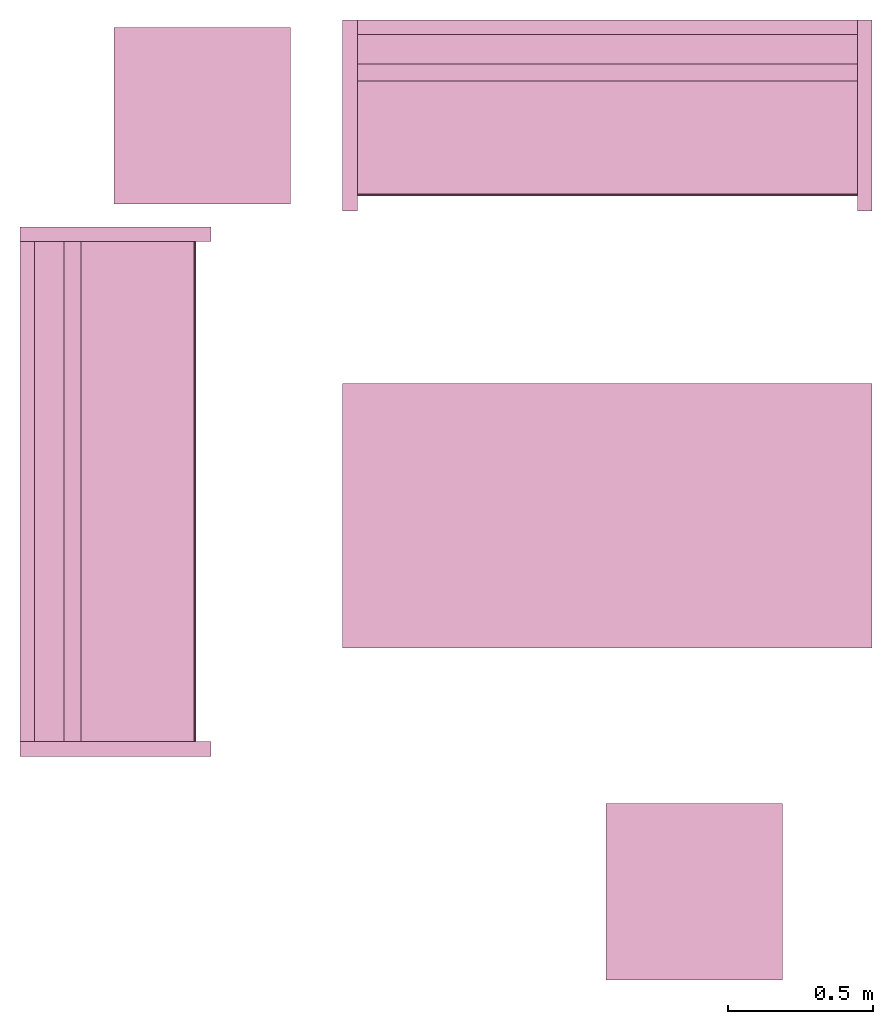
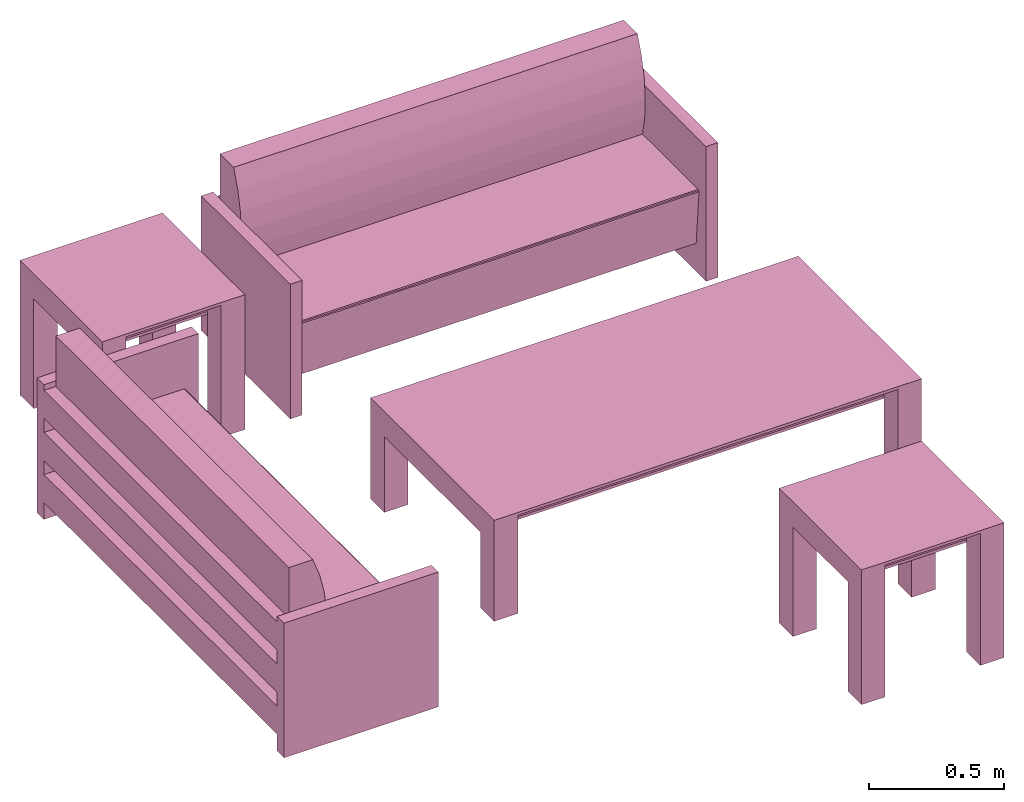
# One storey: 5 furnishings.
"""IFC2X3 building model written with IfcOpenShell, lengths in metres."""

from ifc_helpers import new_model, entity, si_unit, converted_unit, frame, origin, origin_with_axes, origin_2d_with_axis, place, context, project, spatial, polyline, rectangle, outline, extrude, face_set, surface_model, source, transform, mapped, type_object, type_shapes, element, save


model = new_model("IFC2X3")

# Units and contexts
model_context = context("Model", 3, precision=1e-09, world=origin())
plan_context = context("Plan", 3, precision=1e-09, world=origin())
ifc_project = project(units=[si_unit("LENGTHUNIT", "METRE"), si_unit("AREAUNIT", "SQUARE_METRE"), si_unit("VOLUMEUNIT", "CUBIC_METRE"), converted_unit("PLANEANGLEUNIT", "DEGREE", entity("IfcRatioMeasure", 0.0174532925199433), si_unit("PLANEANGLEUNIT", "RADIAN"), dimensions=[0, 0, 0, 0, 0, 0, 0]), si_unit("TIMEUNIT", "SECOND")], contexts=[model_context, plan_context])

# Site, building, storey, space
site_placement = place(None, origin_with_axes())
site = spatial("IfcSite", under=ifc_project, at=site_placement, CompositionType="ELEMENT")
building_placement = place(None, origin_with_axes())
building = spatial("IfcBuilding", under=site, at=building_placement, CompositionType="ELEMENT")
storey_placement = place(None, origin_with_axes())
storey = spatial("IfcBuildingStorey", under=building, at=storey_placement, Name="Level 1", CompositionType="ELEMENT", Elevation=0.0)
space_placement = place(None, origin_with_axes())
space = spatial("IfcSpace", under=storey, at=space_placement, CompositionType="ELEMENT", InteriorOrExteriorSpace="INTERNAL")

# Furnishings
furniture_type_1 = type_object("IfcFurnitureType", Name="0610 x 0610 x 0610mm", AssemblyPlace="NOTDEFINED")
shared_shape_1 = source(origin(), model_context, "Body", "SweptSolid", [
    extrude(rectangle(XDim=0.406799999999999, YDim=0.406799999999999, at=origin_2d_with_axis()), frame((0.0182657666726316, 0.0952110778022263, 0.4957), z_axis=(0.0, 0.0, 1.0), x_axis=(-1.0, 0.0, 0.0)), (0.0, 0.0, 1.0), 0.0127),
    extrude(outline(polyline([(-0.273249999999994, -0.305), (0.324049999999978, -0.305), (0.324049999999978, 0.304999999999998), (-0.273249999999993, 0.304999999999999), (-0.273249999999993, 0.203400000000001), (0.222450000000009, 0.203400000000001), (0.222450000000009, -0.2034), (-0.273249999999994, -0.2034), (-0.273249999999994, -0.305)])), frame((0.221665766672633, 0.0952110778022354, 0.273249999999992), z_axis=(1.0, 0.0, 0.0), x_axis=(0.0, 0.0, 1.0)), (0.0, 0.0, 1.0), 0.1016),
    extrude(outline(polyline([(-0.305000000000004, -0.324050000000025), (0.304999999999994, -0.324050000000025), (0.304999999999994, 0.273250000000011), (0.203400000000004, 0.273250000000011), (0.203400000000004, -0.222449999999996), (-0.203399999999995, -0.222449999999996), (-0.203399999999995, 0.273250000000011), (-0.305000000000004, 0.273250000000011), (-0.305000000000004, -0.324050000000025)])), frame((-0.286734233327367, 0.0952110778022256, 0.273250000000008), z_axis=(1.0, 0.0, 0.0), x_axis=(0.0, -1.0, 0.0)), (0.0, 0.0, 1.0), 0.1016),
    extrude(rectangle(XDim=0.406799999999999, YDim=0.406799999999999, at=origin_2d_with_axis()), frame((0.0182657666726316, 0.0952110778022259, 0.5973), z_axis=(0.0, 0.0, 1.0), x_axis=(-1.0, 0.0, 0.0)), (0.0, 0.0, 1.0), 0.0127),
    extrude(outline(polyline([(-0.305, -0.305000000000023), (0.305, -0.305000000000023), (0.305, 0.305000000000023), (-0.305, 0.305000000000023), (-0.305, -0.305000000000023)]), holes=[polyline([(-0.203399999999998, -0.203399999999975), (-0.203399999999998, 0.203400000000025), (0.203400000000001, 0.203400000000025), (0.203400000000001, -0.203399999999975), (-0.203399999999998, -0.203399999999975)])]), frame((0.0182657666726332, 0.0952110778022508, 0.5973), z_axis=(0.0, 0.0, 1.0), x_axis=(-1.0, 0.0, 0.0)), (0.0, 0.0, 1.0), 0.0127),
])
type_shapes(furniture_type_1, [shared_shape_1])
furnishing_1_placement = place(space_placement, frame((2.9191650807394, -16.6431715869351, 0.0), z_axis=(0.0, 0.0, 1.0), x_axis=(-1.0, 0.0, 0.0)))
element("IfcFurnishingElement", 1, at=furnishing_1_placement, inside=space, type_object=furniture_type_1, Name="M_Table-Coffee:0610 x 0610 x 0610mm:0610 x 0610 x 0610mm", context=model_context, shape_type="MappedRepresentation", body=[
    mapped(shared_shape_1, transform((0.0, 0.0, 0.0), scale=1.0)),
])
furnishing_2_placement = place(None, frame((1.21916508073938, -13.9601715869351, 0.0), z_axis=(0.0, 0.0, 1.0), x_axis=(-1.0, 0.0, 0.0)))
element("IfcFurnishingElement", 2, at=furnishing_2_placement, inside=space, type_object=furniture_type_1, Name="M_Table-Coffee:0610 x 0610 x 0610mm:0610 x 0610 x 0610mm", context=model_context, shape_type="MappedRepresentation", body=[
    mapped(shared_shape_1, transform((0.0, 0.0, 0.0), scale=1.0)),
])
furniture_type_2 = type_object("IfcFurnitureType", Name="1830mm", AssemblyPlace="NOTDEFINED")
shared_shape_2 = source(origin(), model_context, "Body", "SurfaceModel", [
    surface_model("IfcFaceBasedSurfaceModel", [(0.0507999999999982, 0.609599999999997, 0.5842), (0.0507999999999983, 0.660399999999998, 0.5842), (0.0507999999999983, 0.660399999999998, 0.4572), (0.0507999999999982, 0.609599999999997, 0.4572), (0.0507999999999982, 0.609599999999998, 0.3937), (0.0507999999999983, 0.660399999999998, 0.3937), (0.0507999999999983, 0.660399999999998, 0.2667), (0.0507999999999982, 0.609599999999998, 0.2667), (0.0507999999999982, 0.609600000000004, 0.2032), (0.0507999999999983, 0.660399999999998, 0.2032), (0.0507999999999983, 0.660399999999998, 0.0762), (0.0507999999999982, 0.609600000000004, 0.0762), (1.77919999999999, 0.609599999999994, 0.5842), (1.77919999999999, 0.609599999999994, 0.4572), (1.77919999999999, 0.660399999999995, 0.4572), (1.77919999999999, 0.660399999999995, 0.5842), (1.77919999999999, 0.609599999999995, 0.3937), (1.77919999999999, 0.609599999999995, 0.2667), (1.77919999999999, 0.660399999999995, 0.2667), (1.77919999999999, 0.660399999999995, 0.3937), (1.77919999999999, 0.609600000000001, 0.2032), (1.77919999999999, 0.609600000000001, 0.0762), (1.77919999999999, 0.660399999999995, 0.0762), (1.77919999999999, 0.660399999999995, 0.2032), (0.0507999999999978, 0.470222395089521, 0.380999999999998), (0.0507999999999978, 0.454401348887885, 0.467831162756508), (0.0507999999999978, 0.450300415835913, 0.555996567971167), (0.0507999999999978, 0.457992845249543, 0.643921438504357), (0.0507999999999978, 0.477341237862486, 0.730035293556011), (0.0507999999999979, 0.507999999999975, 0.812799999999995), (0.0507999999999981, 0.609599999999998, 0.812799999999998), (0.0507999999999981, 0.609599999999998, 0.127966546684697), (0.0507999999999971, 0.0729375586579064, 0.127966546684697), (0.0507999999999971, 0.0520079452978146, 0.367193122067106), (0.0507999999999971, 0.0526336053189921, 0.372382281209352), (0.0507999999999971, 0.0552961957860913, 0.37687999563672), (0.0507999999999971, 0.0595447350023739, 0.379924455784818), (0.0507999999999971, 0.0646596179635799, 0.381000000000001), (1.77919999999998, 0.470222395089517, 0.381000000000001), (1.77919999999998, 0.0646596179635769, 0.381000000000001), (1.77919999999998, 0.059544735002371, 0.379924455784818), (1.77919999999998, 0.0552961957860883, 0.37687999563672), (1.77919999999998, 0.0526336053189891, 0.372382281209352), (1.77919999999998, 0.0520079452978117, 0.367193122067106), (1.77919999999998, 0.0729375586579034, 0.127966546684697), (1.77919999999998, 0.609599999999995, 0.127966546684697), (1.77919999999998, 0.609599999999995, 0.812799999999998), (1.77919999999998, 0.507999999999972, 0.812799999999995), (1.77919999999998, 0.477341237862483, 0.730035293556011), (1.77919999999998, 0.45799284524954, 0.643921438504357), (1.77919999999998, 0.45030041583591, 0.555996567971167), (1.77919999999998, 0.454401348887882, 0.467831162756508), (0.050799984484911, 0.0539648979902268, 0.374631136655807), (1.77919995784759, 0.0539648979902268, 0.374631136655807), (0.050799984484911, 0.0523207746446133, 0.369787722826004), (1.77919995784759, 0.0523207746446133, 0.369787722826004), (1.77919995784759, 0.0621021725237369, 0.380462229251862), (0.050799984484911, 0.0621788389980793, 0.380478352308273), (1.77919995784759, 0.0574204623699188, 0.378402233123779), (0.050799984484911, 0.0574204623699188, 0.378402233123779), (0.0507999999999971, 0.660399999999997, 0.6096), (0.0507999999999971, 0.0, 0.6096), (0.0, 0.0, 0.6096), (0.0, 0.660399999999997, 0.6096), (1.83, 0.660400000000039, 0.6096), (1.83, 0.0, 0.6096), (1.77919999999997, 0.0, 0.6096), (1.77919999999997, 0.660400000000039, 0.6096), (0.0507999999999971, 0.660399999999997, 0.0), (0.0507999999999971, 0.0, 0.0), (0.0, 0.0, 0.0), (0.0, 0.660399999999997, 0.0), (1.83, 0.660400000000039, 0.0), (1.83, 0.0, 0.0), (1.77919999999997, 0.0, 0.0), (1.77919999999997, 0.660400000000039, 0.0)], [face_set([[[0, 1, 2, 3]], [[4, 5, 6, 7]], [[8, 9, 10, 11]], [[12, 13, 14, 15]], [[16, 17, 18, 19]], [[20, 21, 22, 23]], [[1, 15, 12, 0]], [[2, 14, 15, 1]], [[3, 2, 14, 13]], [[0, 3, 13, 12]], [[5, 19, 16, 4]], [[6, 18, 19, 5]], [[7, 6, 18, 17]], [[4, 7, 17, 16]], [[9, 23, 20, 8]], [[10, 22, 23, 9]], [[11, 10, 22, 21]], [[8, 11, 21, 20]]]), face_set([[[24, 25, 26, 27, 28, 29, 30, 31, 32, 33, 34, 35, 36, 37]], [[38, 39, 40, 41, 42, 43, 44, 45, 46, 47, 48, 49, 50, 51]], [[24, 25, 51, 38]], [[25, 26, 50, 51]], [[49, 50, 26, 27]], [[27, 28, 48, 49]], [[28, 29, 47, 48]], [[30, 46, 47, 29]], [[31, 30, 46, 45]], [[32, 31, 45, 44]], [[33, 32, 44, 43]], [[41, 35, 52, 53]], [[54, 55, 42, 34]], [[33, 43, 55, 54]], [[34, 42, 53, 52]], [[39, 56, 57]], [[35, 41, 58, 59]], [[56, 40, 36]], [[57, 37, 39]], [[57, 56, 36]], [[40, 36, 59, 58]], [[24, 38, 39, 37]]]), face_set([[[60, 61, 62, 63]], [[64, 65, 66, 67]], [[68, 69, 70, 71]], [[72, 73, 74, 75]], [[63, 60, 68, 71]], [[62, 63, 71, 70]], [[61, 62, 70, 69]], [[60, 68, 69, 61]], [[67, 64, 72, 75]], [[66, 74, 75, 67]], [[65, 66, 74, 73]], [[64, 65, 73, 72]]])]),
])
type_shapes(furniture_type_2, [shared_shape_2])
for number, where, z_axis, x_axis, name in (
    (3, (1.23109931406676, -16.2703826647373, 0.0), (0.0, 0.0, 1.0), (0.0, 1.0, 0.0), "M_Sofa:1830mm:1830mm"),
    (4, (1.68589931406676, -14.3855826647373, 0.0), (0.0, 0.0, 1.0), (1.0, 0.0, 0.0), "M_Sofa:1830mm:1830mm"),
):
    element("IfcFurnishingElement", number, at=place(None, frame(where, z_axis=z_axis, x_axis=x_axis)), inside=space, type_object=furniture_type_2, Name=name, context=model_context, shape_type="MappedRepresentation", body=[
        mapped(shared_shape_2, transform((0.0, 0.0, 0.0), scale=1.0)),
    ])
furniture_type_3 = type_object("IfcFurnitureType", Name="0915 x 1830 x 0457mm", AssemblyPlace="NOTDEFINED")
shared_shape_3 = source(origin(), model_context, "Body", "SweptSolid", [
    extrude(rectangle(XDim=1.6268, YDim=0.711799999999999, at=origin_2d_with_axis()), frame((0.0182657666726317, 0.0952110778022268, 0.3427), z_axis=(0.0, 0.0, 1.0), x_axis=(-1.0, 0.0, 0.0)), (0.0, 0.0, 1.0), 0.0127),
    extrude(outline(polyline([(-0.196749999999994, -0.4575), (0.247549999999978, -0.4575), (0.247549999999978, 0.457499999999999), (-0.196749999999993, 0.457499999999999), (-0.196749999999993, 0.355900000000002), (0.145950000000009, 0.355900000000001), (0.145950000000009, -0.3559), (-0.196749999999994, -0.3559), (-0.196749999999994, -0.4575)])), frame((0.831665766672632, 0.0952110778022354, 0.196749999999991), z_axis=(1.0, 0.0, 0.0), x_axis=(0.0, 0.0, 1.0)), (0.0, 0.0, 1.0), 0.1016),
    extrude(outline(polyline([(-0.457500000000004, -0.247550000000026), (0.457499999999994, -0.247550000000026), (0.457499999999994, 0.196750000000011), (0.355900000000004, 0.196750000000011), (0.355900000000004, -0.145949999999996), (-0.355899999999994, -0.145949999999996), (-0.355899999999994, 0.196750000000011), (-0.457500000000004, 0.196750000000011), (-0.457500000000004, -0.247550000000026)])), frame((-0.896734233327367, 0.0952110778022256, 0.196750000000009), z_axis=(1.0, 0.0, 0.0), x_axis=(0.0, -1.0, 0.0)), (0.0, 0.0, 1.0), 0.1016),
    extrude(rectangle(XDim=1.6268, YDim=0.711799999999999, at=origin_2d_with_axis()), frame((0.0182657666726317, 0.0952110778022265, 0.4443), z_axis=(0.0, 0.0, 1.0), x_axis=(-1.0, 0.0, 0.0)), (0.0, 0.0, 1.0), 0.0127),
    extrude(outline(polyline([(-0.915, -0.457500000000023), (0.915, -0.457500000000023), (0.915, 0.457500000000023), (-0.915, 0.457500000000023), (-0.915, -0.457500000000023)]), holes=[polyline([(-0.813399999999998, -0.355899999999975), (-0.813399999999998, 0.355900000000025), (0.813400000000001, 0.355900000000024), (0.813400000000001, -0.355899999999975), (-0.813399999999998, -0.355899999999975)])]), frame((0.0182657666726332, 0.0952110778022514, 0.4443), z_axis=(0.0, 0.0, 1.0), x_axis=(-1.0, 0.0, 0.0)), (0.0, 0.0, 1.0), 0.0127),
])
type_shapes(furniture_type_3, [shared_shape_3])
furnishing_3_placement = place(None, frame((2.61916508073939, -15.3431715869351, 0.0), z_axis=(0.0, 0.0, 1.0), x_axis=(-1.0, 0.0, 0.0)))
element("IfcFurnishingElement", 5, at=furnishing_3_placement, inside=space, type_object=furniture_type_3, Name="M_Table-Coffee:0915 x 1830 x 0457mm:0915 x 1830 x 0457mm", context=model_context, shape_type="MappedRepresentation", body=[
    mapped(shared_shape_3, transform((0.0, 0.0, 0.0), scale=1.0)),
])

save(model, "model.ifc")
